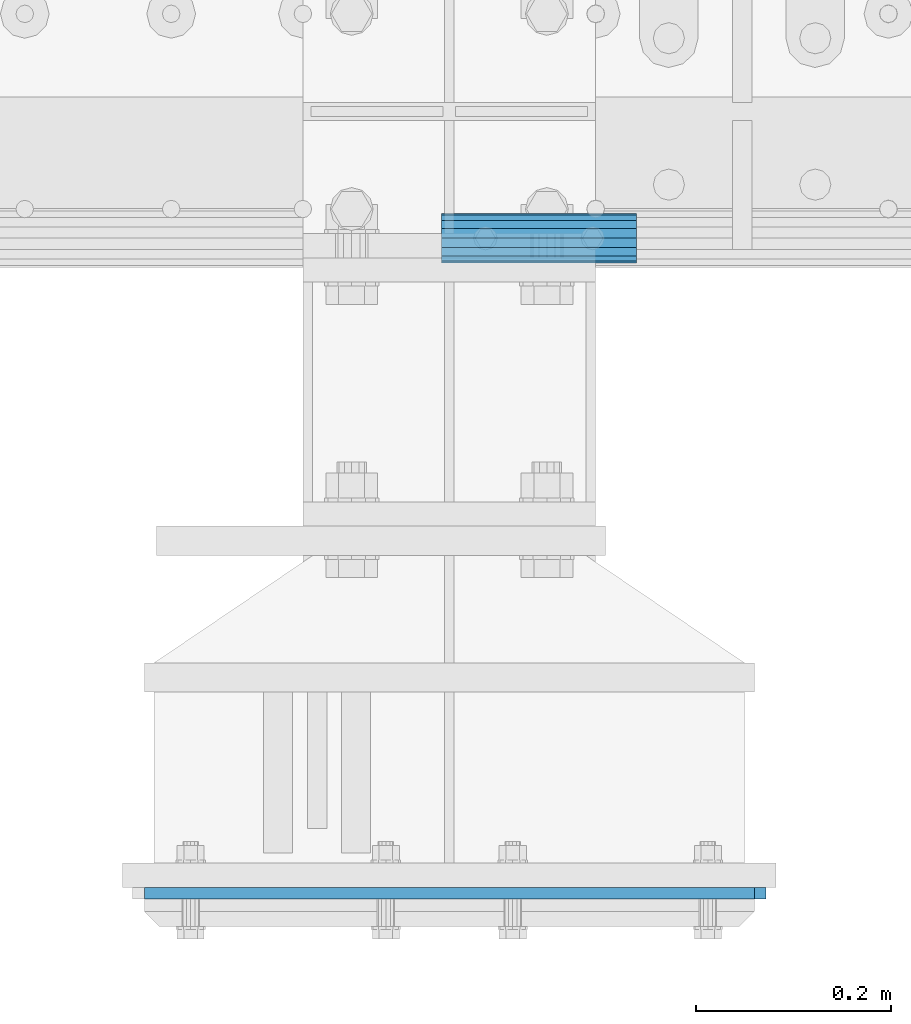
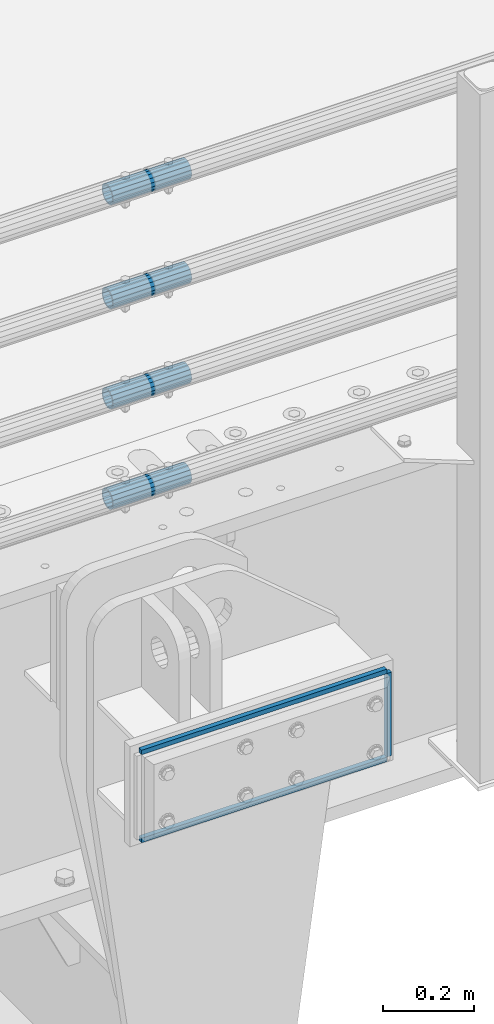
# One storey, part 150 of 242: 7 beams.
"""IFC2X3 building model written with IfcOpenShell, lengths in millimetres."""

import ifcopenshell
import ifcopenshell.guid

model = None  # the IFC model being written
_history = None  # IfcOwnerHistory: only IFC2X3 demands one
_inside = {}  # id of a spatial element -> (the spatial element, [elements in it])
_under = {}  # id of a project, library or spatial element -> (it, [spatial elements below it])
_declared = {}  # id of a project -> (the project, [libraries it declares])
_typed = {}  # id of a type object -> (the type object, [elements of that type])
_made_of = {}  # id of a material, layer set ... -> (it, [elements and type objects made of it])


def new_model(schema):
    """Start an empty IFC model of exactly this schema.

    Asked for "IFC4X3", IfcOpenShell would pick the latest addendum, in which some entities
    have other attributes; the version numbers below select the first issue.
    IFC2X3 requires an IfcOwnerHistory on every rooted entity: one is made here for all.
    """
    global model, _history
    if schema == "IFC4X3":
        model = ifcopenshell.file(schema_version=(4, 3, 0, 0))
    else:
        model = ifcopenshell.file(schema=schema)
    _inside.clear()
    _under.clear()
    _declared.clear()
    _typed.clear()
    _made_of.clear()
    _history = None
    if model.schema == "IFC2X3":
        org = make("IfcOrganization", Name="unknown")
        user = make(
            "IfcPersonAndOrganization",
            ThePerson=make("IfcPerson", FamilyName="unknown"),
            TheOrganization=org,
        )
        app = make(
            "IfcApplication",
            ApplicationDeveloper=org,
            Version="unknown",
            ApplicationFullName="unknown",
            ApplicationIdentifier="unknown",
        )
        _history = make(
            "IfcOwnerHistory",
            OwningUser=user,
            OwningApplication=app,
            ChangeAction="ADDED",
            CreationDate=0,
        )
    return model


def make(cls, **values):
    """One entity of the class cls with the attributes given. An attribute that is None is left unset."""
    return model.create_entity(
        cls, **{name: value for name, value in values.items() if value is not None}
    )


def rooted(cls, **values):
    """An entity with a GlobalId (a new one), such as an element, a storey or a relation."""
    return make(cls, GlobalId=ifcopenshell.guid.new(), OwnerHistory=_history, **values)


def si_unit(unit_type, name, prefix=None):
    """IfcSIUnit, for example si_unit("LENGTHUNIT", "METRE", prefix="MILLI")."""
    return make("IfcSIUnit", UnitType=unit_type, Prefix=prefix, Name=name)


def assignment(units):
    """IfcUnitAssignment: the units of a project."""
    return None if units is None else make("IfcUnitAssignment", Units=units)


def point(xyz):
    """IfcCartesianPoint."""
    return None if xyz is None else make("IfcCartesianPoint", Coordinates=xyz)


def direction(xyz):
    """IfcDirection."""
    return None if xyz is None else make("IfcDirection", DirectionRatios=xyz)


def frame(location, z_axis=None, x_axis=None):
    """IfcAxis2Placement3D, a coordinate frame: its origin and axes. An axis left out is left unset."""
    return make(
        "IfcAxis2Placement3D",
        Location=point(location),
        Axis=direction(z_axis),
        RefDirection=direction(x_axis),
    )


def origin_with_axes():
    """The frame at (0, 0, 0) with the z axis (0, 0, 1) and the x axis (1, 0, 0) written out."""
    return frame((0.0, 0.0, 0.0), z_axis=(0.0, 0.0, 1.0), x_axis=(1.0, 0.0, 0.0))


def place(relative_to, where):
    """IfcLocalPlacement: puts the frame where relative to a parent placement (None: the world)."""
    return make(
        "IfcLocalPlacement", PlacementRelTo=relative_to, RelativePlacement=where
    )


def context(
    kind, dimensions, precision=None, world=None, true_north=None, identifier=None
):
    """IfcGeometricRepresentationContext, for example the 3D "Model" context."""
    return make(
        "IfcGeometricRepresentationContext",
        ContextIdentifier=identifier,
        ContextType=kind,
        CoordinateSpaceDimension=dimensions,
        Precision=precision,
        WorldCoordinateSystem=world,
        TrueNorth=true_north,
    )


def subcontext(parent, identifier, kind, view, scale=None):
    """IfcGeometricRepresentationSubContext, for example "Body" below "Model"."""
    return make(
        "IfcGeometricRepresentationSubContext",
        ContextIdentifier=identifier,
        ContextType=kind,
        ParentContext=parent,
        TargetScale=scale,
        TargetView=view,
    )


def project(units=None, contexts=None):
    """IfcProject with its units and contexts."""
    return rooted(
        "IfcProject",
        Name="project",
        RepresentationContexts=contexts,
        UnitsInContext=assignment(units),
    )


def spatial(cls, under=None, at=None, **own):
    """A site, building, storey or space (cls), placed at a placement, below another one or the project."""
    s = rooted(cls, ObjectPlacement=at, **own)
    if under is not None:
        _under.setdefault(under.id(), (under, []))[1].append(s)
    return s


def faces_of(points, faces, orient=None, outer=None):
    """IfcFace entities. A face is a list of loops; a loop is a list of indices into points, from 0.

    orient and outer hold one flag for each loop. By default every Orientation is true, the
    first loop of a face is its IfcFaceOuterBound and the others are IfcFaceBound.
    """
    made = []
    for i, loops in enumerate(faces):
        bounds = []
        for j, loop in enumerate(loops):
            is_outer = j == 0 if outer is None else outer[i][j]
            bounds.append(
                make(
                    "IfcFaceOuterBound" if is_outer else "IfcFaceBound",
                    Bound=make("IfcPolyLoop", Polygon=[points[k] for k in loop]),
                    Orientation=True if orient is None else orient[i][j],
                )
            )
        made.append(make("IfcFace", Bounds=bounds))
    return made


def faceted_brep(points, faces, orient=None, outer=None, voids=None):
    """IfcFacetedBrep: a solid bounded by flat faces; with voids (closed shells), ...WithVoids."""
    shared = [point(p) for p in points]
    hull = make("IfcClosedShell", CfsFaces=faces_of(shared, faces, orient, outer))
    if voids is None:
        return make("IfcFacetedBrep", Outer=hull)
    return make(
        "IfcFacetedBrepWithVoids",
        Outer=hull,
        Voids=[
            make(cls, CfsFaces=faces_of(shared, fs, o, b)) for cls, fs, o, b in voids
        ],
    )


def shape(context_of_items, identifier, shape_type, items):
    """IfcShapeRepresentation: the items that make up one representation, for example the "Body"."""
    return make(
        "IfcShapeRepresentation",
        ContextOfItems=context_of_items,
        RepresentationIdentifier=identifier,
        RepresentationType=shape_type,
        Items=items,
    )


def material(Name=None, Category=None):
    """IfcMaterial."""
    return make("IfcMaterial", Name=Name, Category=Category)


def made_of(thing, what):
    """Note that an element or type object is made of a material, layer set ...; save() writes the relation."""
    if what is not None:
        _made_of.setdefault(what.id(), (what, []))[1].append(thing)
    return thing


def type_object(cls, material=None, **own):
    """A type object (cls), such as IfcWallType, which elements share."""
    return made_of(rooted(cls, **own), material)


def element(
    cls,
    number,
    at=None,
    inside=None,
    cuts=None,
    type_object=None,
    material=None,
    context=None,
    identifier="Body",
    shape_type=None,
    held_by="IfcProductDefinitionShape",
    body=None,
    shapes=None,
    **own,
):
    """One element of the class cls, such as IfcWall. Its Tag is "e" and its number.

    at: its placement. inside: the storey or other place that contains it. cuts: it is an
    opening in that element (IfcRelVoidsElement). A single representation is given by context,
    identifier, shape_type and body (its items); several are given by shapes. held_by: the class
    of the entity that holds the representations. save() writes the other relations.
    """
    e = rooted(cls, Tag="e%d" % number, ObjectPlacement=at, **own)
    if body is not None:
        shapes = [shape(context, identifier, shape_type, body)]
    if shapes is not None:
        e.Representation = make(held_by, Representations=shapes)
    if inside is not None:
        _inside.setdefault(inside.id(), (inside, []))[1].append(e)
    if cuts is not None:
        rooted(
            "IfcRelVoidsElement", RelatingBuildingElement=cuts, RelatedOpeningElement=e
        )
    if type_object is not None:
        _typed.setdefault(type_object.id(), (type_object, []))[1].append(e)
    return made_of(e, material)


def aggregate(whole, parts):
    """IfcRelAggregates: a whole, such as a stair, and the parts it consists of."""
    return rooted("IfcRelAggregates", RelatingObject=whole, RelatedObjects=parts)


def save(model, path):
    """Write the relations noted so far, then the file.

    IfcRelAggregates (storeys below a building ...), IfcRelContainedInSpatialStructure (elements
    in a storey), IfcRelDefinesByType, IfcRelAssociatesMaterial and IfcRelDeclares: one each for
    every whole, place, type object, material and project.
    """
    for whole, parts in _under.values():
        aggregate(whole, parts)
    for where, things in _inside.values():
        rooted(
            "IfcRelContainedInSpatialStructure",
            RelatedElements=things,
            RelatingStructure=where,
        )
    for kind, things in _typed.values():
        rooted("IfcRelDefinesByType", RelatedObjects=things, RelatingType=kind)
    for what, things in _made_of.values():
        rooted("IfcRelAssociatesMaterial", RelatedObjects=things, RelatingMaterial=what)
    for by, libraries in _declared.values():
        rooted("IfcRelDeclares", RelatingContext=by, RelatedDefinitions=libraries)
    model.write(path)


model = new_model("IFC2X3")

# Units and contexts
model_context = context("Model", 3, precision=1e-05, world=origin_with_axes())
body_context = subcontext(model_context, "Body", "Model", "MODEL_VIEW")
ifc_project = project(units=[si_unit("LENGTHUNIT", "METRE", prefix="MILLI"), si_unit("AREAUNIT", "SQUARE_METRE"), si_unit("VOLUMEUNIT", "CUBIC_METRE"), si_unit("MASSUNIT", "GRAM", prefix="KILO"), si_unit("TIMEUNIT", "SECOND"), si_unit("PLANEANGLEUNIT", "RADIAN"), si_unit("SOLIDANGLEUNIT", "STERADIAN"), si_unit("THERMODYNAMICTEMPERATUREUNIT", "DEGREE_CELSIUS"), si_unit("LUMINOUSINTENSITYUNIT", "LUMEN")], contexts=[model_context])

# Site, building, storey
site_placement = place(None, origin_with_axes())
site = spatial("IfcSite", under=ifc_project, at=site_placement, CompositionType="ELEMENT")
building_placement = place(site_placement, origin_with_axes())
building = spatial("IfcBuilding", under=site, at=building_placement, Name="Standard", CompositionType="ELEMENT")
storey_placement = place(building_placement, origin_with_axes())
storey = spatial("IfcBuildingStorey", under=building, at=storey_placement, Name="Undefined", CompositionType="ELEMENT", Elevation=0.0)

# Beams
ifc_material_1 = material()
beam_type_1 = type_object("IfcBeamType", PredefinedType="NOTDEFINED")
beam_1_placement = place(storey_placement, frame((-28423.0024970001, -24129.8499999996, 149.849999999726), z_axis=(0.0, 0.0, 1.0), x_axis=(1.0, 0.0, 0.0)))
element("IfcBeam", 1, at=beam_1_placement, inside=storey, type_object=beam_type_1, material=ifc_material_1, context=body_context, shape_type="Brep", body=[
    faceted_brep([(0.0, -21.9000000000015, 0.0), (0.0, -20.232961761998, 8.38076716879547), (200.0, -20.232961761998, 8.38076716879547), (200.0, -21.9000000000015, 0.0), (0.0, -15.4856385079838, 15.4856385079854), (200.0, -15.4856385079838, 15.4856385079854), (0.0, -8.38076716879368, 20.2329617619972), (200.0, -8.38076716879368, 20.2329617619972), (0.0, 0.0, 21.9), (200.0, 0.0, 21.9), (0.0, 8.38076716879368, 20.2329617619972), (200.0, 8.38076716879368, 20.2329617619972), (0.0, 15.4856385079838, 15.4856385079854), (200.0, 15.4856385079838, 15.4856385079854), (0.0, 20.232961761998, 8.38076716879547), (200.0, 20.232961761998, 8.38076716879547), (0.0, 21.9000000000015, 0.0), (200.0, 21.9000000000015, 0.0), (0.0, 20.232961761998, -8.38076716879547), (200.0, 20.232961761998, -8.38076716879547), (0.0, 15.4856385079838, -15.4856385079854), (200.0, 15.4856385079838, -15.4856385079854), (0.0, 8.38076716879368, -20.2329617619972), (200.0, 8.38076716879368, -20.2329617619972), (0.0, 0.0, -21.9), (200.0, 0.0, -21.9), (0.0, -8.38076716879368, -20.2329617619972), (200.0, -8.38076716879368, -20.2329617619972), (0.0, -15.4856385079838, -15.4856385079854), (200.0, -15.4856385079838, -15.4856385079854), (0.0, -20.232961761998, -8.38076716879547), (200.0, -20.232961761998, -8.38076716879547), (0.0, -25.5, 0.0), (0.0, -23.5589280790373, -9.7584275253098), (200.0, -23.5589280790373, -9.7584275253098), (200.0, -25.5, 0.0), (0.0, -18.0312229202573, -18.031222920257), (200.0, -18.0312229202573, -18.031222920257), (0.0, -9.75842752531025, -23.5589280790378), (200.0, -9.75842752531025, -23.5589280790378), (0.0, 0.0, -25.5), (200.0, 0.0, -25.5), (0.0, 9.75842752531025, -23.5589280790378), (200.0, 9.75842752531025, -23.5589280790378), (0.0, 18.0312229202573, -18.031222920257), (200.0, 18.0312229202573, -18.031222920257), (0.0, 23.5589280790373, -9.7584275253098), (200.0, 23.5589280790373, -9.7584275253098), (0.0, 25.5, 0.0), (200.0, 25.5, 0.0), (0.0, 23.5589280790373, 9.7584275253098), (200.0, 23.5589280790373, 9.7584275253098), (0.0, 18.0312229202573, 18.031222920257), (200.0, 18.0312229202573, 18.031222920257), (0.0, 9.75842752531025, 23.5589280790378), (200.0, 9.75842752531025, 23.5589280790378), (0.0, 0.0, 25.5), (200.0, 0.0, 25.5), (0.0, -9.75842752531025, 23.5589280790378), (200.0, -9.75842752531025, 23.5589280790378), (0.0, -18.0312229202573, 18.031222920257), (200.0, -18.0312229202573, 18.031222920257), (0.0, -23.5589280790373, 9.7584275253098), (200.0, -23.5589280790373, 9.7584275253098)], [[[0, 1, 2, 3]], [[1, 4, 5, 2]], [[4, 6, 7, 5]], [[6, 8, 9, 7]], [[8, 10, 11, 9]], [[10, 12, 13, 11]], [[12, 14, 15, 13]], [[14, 16, 17, 15]], [[16, 18, 19, 17]], [[18, 20, 21, 19]], [[20, 22, 23, 21]], [[22, 24, 25, 23]], [[24, 26, 27, 25]], [[26, 28, 29, 27]], [[28, 30, 31, 29]], [[30, 0, 3, 31]], [[32, 33, 34, 35]], [[33, 36, 37, 34]], [[36, 38, 39, 37]], [[38, 40, 41, 39]], [[40, 42, 43, 41]], [[42, 44, 45, 43]], [[44, 46, 47, 45]], [[46, 48, 49, 47]], [[48, 50, 51, 49]], [[50, 52, 53, 51]], [[52, 54, 55, 53]], [[54, 56, 57, 55]], [[56, 58, 59, 57]], [[58, 60, 61, 59]], [[60, 62, 63, 61]], [[62, 32, 35, 63]], [[37, 39, 41, 43, 45, 47, 49, 51, 53, 55, 57, 59, 61, 63, 35, 34], [5, 7, 9, 11, 13, 15, 17, 19, 21, 23, 25, 27, 29, 31, 3, 2]], [[62, 60, 58, 56, 54, 52, 50, 48, 46, 44, 42, 40, 38, 36, 33, 32], [30, 28, 26, 24, 22, 20, 18, 16, 14, 12, 10, 8, 6, 4, 1, 0]]]),
])
beam_2_placement = place(storey_placement, frame((-28423.0024970001, -24129.8499999996, 420.149999999725), z_axis=(0.0, 0.0, 1.0), x_axis=(1.0, 0.0, 0.0)))
element("IfcBeam", 2, at=beam_2_placement, inside=storey, type_object=beam_type_1, material=ifc_material_1, context=body_context, shape_type="Brep", body=[
    faceted_brep([(0.0, -21.9000000000015, 0.0), (0.0, -20.232961761998, 8.38076716879547), (200.0, -20.232961761998, 8.38076716879547), (200.0, -21.9000000000015, 0.0), (0.0, -15.4856385079838, 15.4856385079854), (200.0, -15.4856385079838, 15.4856385079854), (0.0, -8.38076716879368, 20.2329617619972), (200.0, -8.38076716879368, 20.2329617619972), (0.0, 0.0, 21.9), (200.0, 0.0, 21.9), (0.0, 8.38076716879368, 20.2329617619972), (200.0, 8.38076716879368, 20.2329617619972), (0.0, 15.4856385079838, 15.4856385079854), (200.0, 15.4856385079838, 15.4856385079854), (0.0, 20.232961761998, 8.38076716879547), (200.0, 20.232961761998, 8.38076716879547), (0.0, 21.9000000000015, 0.0), (200.0, 21.9000000000015, 0.0), (0.0, 20.232961761998, -8.38076716879547), (200.0, 20.232961761998, -8.38076716879547), (0.0, 15.4856385079838, -15.4856385079854), (200.0, 15.4856385079838, -15.4856385079854), (0.0, 8.38076716879368, -20.2329617619972), (200.0, 8.38076716879368, -20.2329617619972), (0.0, 0.0, -21.9), (200.0, 0.0, -21.9), (0.0, -8.38076716879368, -20.2329617619972), (200.0, -8.38076716879368, -20.2329617619972), (0.0, -15.4856385079838, -15.4856385079854), (200.0, -15.4856385079838, -15.4856385079854), (0.0, -20.232961761998, -8.38076716879547), (200.0, -20.232961761998, -8.38076716879547), (0.0, -25.5, 0.0), (0.0, -23.5589280790373, -9.7584275253098), (200.0, -23.5589280790373, -9.7584275253098), (200.0, -25.5, 0.0), (0.0, -18.0312229202573, -18.031222920257), (200.0, -18.0312229202573, -18.031222920257), (0.0, -9.75842752531025, -23.5589280790378), (200.0, -9.75842752531025, -23.5589280790378), (0.0, 0.0, -25.5), (200.0, 0.0, -25.5), (0.0, 9.75842752531025, -23.5589280790378), (200.0, 9.75842752531025, -23.5589280790378), (0.0, 18.0312229202573, -18.031222920257), (200.0, 18.0312229202573, -18.031222920257), (0.0, 23.5589280790373, -9.7584275253098), (200.0, 23.5589280790373, -9.7584275253098), (0.0, 25.5, 0.0), (200.0, 25.5, 0.0), (0.0, 23.5589280790373, 9.7584275253098), (200.0, 23.5589280790373, 9.7584275253098), (0.0, 18.0312229202573, 18.031222920257), (200.0, 18.0312229202573, 18.031222920257), (0.0, 9.75842752531025, 23.5589280790378), (200.0, 9.75842752531025, 23.5589280790378), (0.0, 0.0, 25.5), (200.0, 0.0, 25.5), (0.0, -9.75842752531025, 23.5589280790378), (200.0, -9.75842752531025, 23.5589280790378), (0.0, -18.0312229202573, 18.031222920257), (200.0, -18.0312229202573, 18.031222920257), (0.0, -23.5589280790373, 9.7584275253098), (200.0, -23.5589280790373, 9.7584275253098)], [[[0, 1, 2, 3]], [[1, 4, 5, 2]], [[4, 6, 7, 5]], [[6, 8, 9, 7]], [[8, 10, 11, 9]], [[10, 12, 13, 11]], [[12, 14, 15, 13]], [[14, 16, 17, 15]], [[16, 18, 19, 17]], [[18, 20, 21, 19]], [[20, 22, 23, 21]], [[22, 24, 25, 23]], [[24, 26, 27, 25]], [[26, 28, 29, 27]], [[28, 30, 31, 29]], [[30, 0, 3, 31]], [[32, 33, 34, 35]], [[33, 36, 37, 34]], [[36, 38, 39, 37]], [[38, 40, 41, 39]], [[40, 42, 43, 41]], [[42, 44, 45, 43]], [[44, 46, 47, 45]], [[46, 48, 49, 47]], [[48, 50, 51, 49]], [[50, 52, 53, 51]], [[52, 54, 55, 53]], [[54, 56, 57, 55]], [[56, 58, 59, 57]], [[58, 60, 61, 59]], [[60, 62, 63, 61]], [[62, 32, 35, 63]], [[37, 39, 41, 43, 45, 47, 49, 51, 53, 55, 57, 59, 61, 63, 35, 34], [5, 7, 9, 11, 13, 15, 17, 19, 21, 23, 25, 27, 29, 31, 3, 2]], [[62, 60, 58, 56, 54, 52, 50, 48, 46, 44, 42, 40, 38, 36, 33, 32], [30, 28, 26, 24, 22, 20, 18, 16, 14, 12, 10, 8, 6, 4, 1, 0]]]),
])
beam_3_placement = place(storey_placement, frame((-28423.0024970001, -24129.8499999996, 969.849999999726), z_axis=(0.0, 0.0, 1.0), x_axis=(1.0, 0.0, 0.0)))
element("IfcBeam", 3, at=beam_3_placement, inside=storey, type_object=beam_type_1, material=ifc_material_1, context=body_context, shape_type="Brep", body=[
    faceted_brep([(0.0, -21.9000000000015, 0.0), (0.0, -20.232961761998, 8.38076716879547), (200.0, -20.232961761998, 8.38076716879547), (200.0, -21.9000000000015, 0.0), (0.0, -15.4856385079838, 15.4856385079854), (200.0, -15.4856385079838, 15.4856385079854), (0.0, -8.38076716879368, 20.2329617619972), (200.0, -8.38076716879368, 20.2329617619972), (0.0, 0.0, 21.9), (200.0, 0.0, 21.9), (0.0, 8.38076716879368, 20.2329617619972), (200.0, 8.38076716879368, 20.2329617619972), (0.0, 15.4856385079838, 15.4856385079854), (200.0, 15.4856385079838, 15.4856385079854), (0.0, 20.232961761998, 8.38076716879547), (200.0, 20.232961761998, 8.38076716879547), (0.0, 21.9000000000015, 0.0), (200.0, 21.9000000000015, 0.0), (0.0, 20.232961761998, -8.38076716879547), (200.0, 20.232961761998, -8.38076716879547), (0.0, 15.4856385079838, -15.4856385079854), (200.0, 15.4856385079838, -15.4856385079854), (0.0, 8.38076716879368, -20.2329617619972), (200.0, 8.38076716879368, -20.2329617619972), (0.0, 0.0, -21.9), (200.0, 0.0, -21.9), (0.0, -8.38076716879368, -20.2329617619972), (200.0, -8.38076716879368, -20.2329617619972), (0.0, -15.4856385079838, -15.4856385079854), (200.0, -15.4856385079838, -15.4856385079854), (0.0, -20.232961761998, -8.38076716879547), (200.0, -20.232961761998, -8.38076716879547), (0.0, -25.5, 0.0), (0.0, -23.5589280790373, -9.7584275253098), (200.0, -23.5589280790373, -9.7584275253098), (200.0, -25.5, 0.0), (0.0, -18.0312229202573, -18.031222920257), (200.0, -18.0312229202573, -18.031222920257), (0.0, -9.75842752531025, -23.5589280790378), (200.0, -9.75842752531025, -23.5589280790378), (0.0, 0.0, -25.5), (200.0, 0.0, -25.5), (0.0, 9.75842752531025, -23.5589280790378), (200.0, 9.75842752531025, -23.5589280790378), (0.0, 18.0312229202573, -18.031222920257), (200.0, 18.0312229202573, -18.031222920257), (0.0, 23.5589280790373, -9.7584275253098), (200.0, 23.5589280790373, -9.7584275253098), (0.0, 25.5, 0.0), (200.0, 25.5, 0.0), (0.0, 23.5589280790373, 9.7584275253098), (200.0, 23.5589280790373, 9.7584275253098), (0.0, 18.0312229202573, 18.031222920257), (200.0, 18.0312229202573, 18.031222920257), (0.0, 9.75842752531025, 23.5589280790378), (200.0, 9.75842752531025, 23.5589280790378), (0.0, 0.0, 25.5), (200.0, 0.0, 25.5), (0.0, -9.75842752531025, 23.5589280790378), (200.0, -9.75842752531025, 23.5589280790378), (0.0, -18.0312229202573, 18.031222920257), (200.0, -18.0312229202573, 18.031222920257), (0.0, -23.5589280790373, 9.7584275253098), (200.0, -23.5589280790373, 9.7584275253098)], [[[0, 1, 2, 3]], [[1, 4, 5, 2]], [[4, 6, 7, 5]], [[6, 8, 9, 7]], [[8, 10, 11, 9]], [[10, 12, 13, 11]], [[12, 14, 15, 13]], [[14, 16, 17, 15]], [[16, 18, 19, 17]], [[18, 20, 21, 19]], [[20, 22, 23, 21]], [[22, 24, 25, 23]], [[24, 26, 27, 25]], [[26, 28, 29, 27]], [[28, 30, 31, 29]], [[30, 0, 3, 31]], [[32, 33, 34, 35]], [[33, 36, 37, 34]], [[36, 38, 39, 37]], [[38, 40, 41, 39]], [[40, 42, 43, 41]], [[42, 44, 45, 43]], [[44, 46, 47, 45]], [[46, 48, 49, 47]], [[48, 50, 51, 49]], [[50, 52, 53, 51]], [[52, 54, 55, 53]], [[54, 56, 57, 55]], [[56, 58, 59, 57]], [[58, 60, 61, 59]], [[60, 62, 63, 61]], [[62, 32, 35, 63]], [[37, 39, 41, 43, 45, 47, 49, 51, 53, 55, 57, 59, 61, 63, 35, 34], [5, 7, 9, 11, 13, 15, 17, 19, 21, 23, 25, 27, 29, 31, 3, 2]], [[62, 60, 58, 56, 54, 52, 50, 48, 46, 44, 42, 40, 38, 36, 33, 32], [30, 28, 26, 24, 22, 20, 18, 16, 14, 12, 10, 8, 6, 4, 1, 0]]]),
])
beam_4_placement = place(storey_placement, frame((-28423.0024970001, -24129.8499999996, 689.849999999726), z_axis=(0.0, 0.0, 1.0), x_axis=(1.0, 0.0, 0.0)))
element("IfcBeam", 4, at=beam_4_placement, inside=storey, type_object=beam_type_1, material=ifc_material_1, context=body_context, shape_type="Brep", body=[
    faceted_brep([(0.0, -21.9000000000015, 0.0), (0.0, -20.232961761998, 8.38076716879547), (200.0, -20.232961761998, 8.38076716879547), (200.0, -21.9000000000015, 0.0), (0.0, -15.4856385079838, 15.4856385079854), (200.0, -15.4856385079838, 15.4856385079854), (0.0, -8.38076716879368, 20.2329617619972), (200.0, -8.38076716879368, 20.2329617619972), (0.0, 0.0, 21.9), (200.0, 0.0, 21.9), (0.0, 8.38076716879368, 20.2329617619972), (200.0, 8.38076716879368, 20.2329617619972), (0.0, 15.4856385079838, 15.4856385079854), (200.0, 15.4856385079838, 15.4856385079854), (0.0, 20.232961761998, 8.38076716879547), (200.0, 20.232961761998, 8.38076716879547), (0.0, 21.9000000000015, 0.0), (200.0, 21.9000000000015, 0.0), (0.0, 20.232961761998, -8.38076716879547), (200.0, 20.232961761998, -8.38076716879547), (0.0, 15.4856385079838, -15.4856385079854), (200.0, 15.4856385079838, -15.4856385079854), (0.0, 8.38076716879368, -20.2329617619972), (200.0, 8.38076716879368, -20.2329617619972), (0.0, 0.0, -21.9), (200.0, 0.0, -21.9), (0.0, -8.38076716879368, -20.2329617619972), (200.0, -8.38076716879368, -20.2329617619972), (0.0, -15.4856385079838, -15.4856385079854), (200.0, -15.4856385079838, -15.4856385079854), (0.0, -20.232961761998, -8.38076716879547), (200.0, -20.232961761998, -8.38076716879547), (0.0, -25.5, 0.0), (0.0, -23.5589280790373, -9.7584275253098), (200.0, -23.5589280790373, -9.7584275253098), (200.0, -25.5, 0.0), (0.0, -18.0312229202573, -18.031222920257), (200.0, -18.0312229202573, -18.031222920257), (0.0, -9.75842752531025, -23.5589280790378), (200.0, -9.75842752531025, -23.5589280790378), (0.0, 0.0, -25.5), (200.0, 0.0, -25.5), (0.0, 9.75842752531025, -23.5589280790378), (200.0, 9.75842752531025, -23.5589280790378), (0.0, 18.0312229202573, -18.031222920257), (200.0, 18.0312229202573, -18.031222920257), (0.0, 23.5589280790373, -9.7584275253098), (200.0, 23.5589280790373, -9.7584275253098), (0.0, 25.5, 0.0), (200.0, 25.5, 0.0), (0.0, 23.5589280790373, 9.7584275253098), (200.0, 23.5589280790373, 9.7584275253098), (0.0, 18.0312229202573, 18.031222920257), (200.0, 18.0312229202573, 18.031222920257), (0.0, 9.75842752531025, 23.5589280790378), (200.0, 9.75842752531025, 23.5589280790378), (0.0, 0.0, 25.5), (200.0, 0.0, 25.5), (0.0, -9.75842752531025, 23.5589280790378), (200.0, -9.75842752531025, 23.5589280790378), (0.0, -18.0312229202573, 18.031222920257), (200.0, -18.0312229202573, 18.031222920257), (0.0, -23.5589280790373, 9.7584275253098), (200.0, -23.5589280790373, 9.7584275253098)], [[[0, 1, 2, 3]], [[1, 4, 5, 2]], [[4, 6, 7, 5]], [[6, 8, 9, 7]], [[8, 10, 11, 9]], [[10, 12, 13, 11]], [[12, 14, 15, 13]], [[14, 16, 17, 15]], [[16, 18, 19, 17]], [[18, 20, 21, 19]], [[20, 22, 23, 21]], [[22, 24, 25, 23]], [[24, 26, 27, 25]], [[26, 28, 29, 27]], [[28, 30, 31, 29]], [[30, 0, 3, 31]], [[32, 33, 34, 35]], [[33, 36, 37, 34]], [[36, 38, 39, 37]], [[38, 40, 41, 39]], [[40, 42, 43, 41]], [[42, 44, 45, 43]], [[44, 46, 47, 45]], [[46, 48, 49, 47]], [[48, 50, 51, 49]], [[50, 52, 53, 51]], [[52, 54, 55, 53]], [[54, 56, 57, 55]], [[56, 58, 59, 57]], [[58, 60, 61, 59]], [[60, 62, 63, 61]], [[62, 32, 35, 63]], [[37, 39, 41, 43, 45, 47, 49, 51, 53, 55, 57, 59, 61, 63, 35, 34], [5, 7, 9, 11, 13, 15, 17, 19, 21, 23, 25, 27, 29, 31, 3, 2]], [[62, 60, 58, 56, 54, 52, 50, 48, 46, 44, 42, 40, 38, 36, 33, 32], [30, 28, 26, 24, 22, 20, 18, 16, 14, 12, 10, 8, 6, 4, 1, 0]]]),
])
ifc_material_2 = material(Name="STEEL/S355N")
beam_type_2 = type_object("IfcBeamType", PredefinedType="NOTDEFINED")
beam_5_placement = place(storey_placement, frame((-28096.4999999398, -24801.000000035, -22.5000182225592), z_axis=(-1.0, 0.0, 0.0), x_axis=(0.0, 0.0, -1.0)))
element("IfcBeam", 5, at=beam_5_placement, inside=storey, type_object=beam_type_2, material=ifc_material_2, context=body_context, shape_type="Brep", body=[
    faceted_brep([(0.0, 6.0, -6.0), (0.0, 6.0, 6.0), (225.0, 6.0, 6.0), (225.0, 6.0, -6.0), (0.0, -6.0, 6.0), (225.0, -6.0, 6.0), (0.0, -6.0, -6.0), (225.0, -6.0, -6.0)], [[[0, 1, 2, 3]], [[1, 4, 5, 2]], [[4, 6, 7, 5]], [[6, 0, 3, 7]], [[5, 7, 3, 2]], [[6, 4, 1, 0]]]),
])
for number, where, z_axis, x_axis in (
    (6, (-28727.4999999415, -24801.0000000349, -16.5000182225592), (0.0, 0.0, -1.0), (1.0, 0.0, 0.0)),
    (7, (-28727.4999999415, -24801.0000000349, -253.500018222559), (0.0, 0.0, -1.0), (1.0, 0.0, 0.0)),
):
    element("IfcBeam", number, at=place(storey_placement, frame(where, z_axis=z_axis, x_axis=x_axis)), inside=storey, type_object=beam_type_2, material=ifc_material_2, context=body_context, shape_type="Brep", body=[
        faceted_brep([(0.0, 6.0, -6.0), (0.0, 6.0, 6.0), (625.000000001688, 6.0, 6.0), (625.000000001688, 6.0, -6.0), (0.0, -6.0, 6.0), (625.000000001688, -6.0, 6.0), (0.0, -6.0, -6.0), (625.000000001688, -6.0, -6.0)], [[[0, 1, 2, 3]], [[1, 4, 5, 2]], [[4, 6, 7, 5]], [[6, 0, 3, 7]], [[5, 7, 3, 2]], [[6, 4, 1, 0]]]),
    ])

save(model, "model.ifc")
